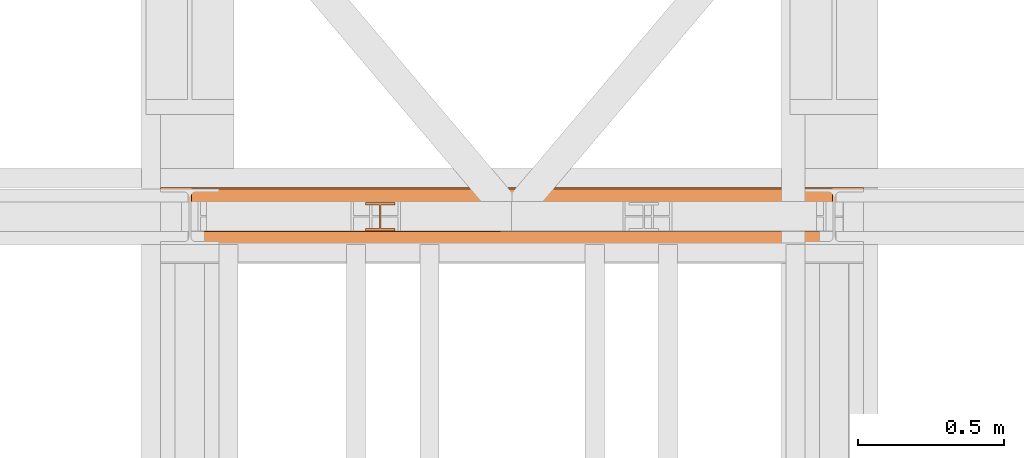
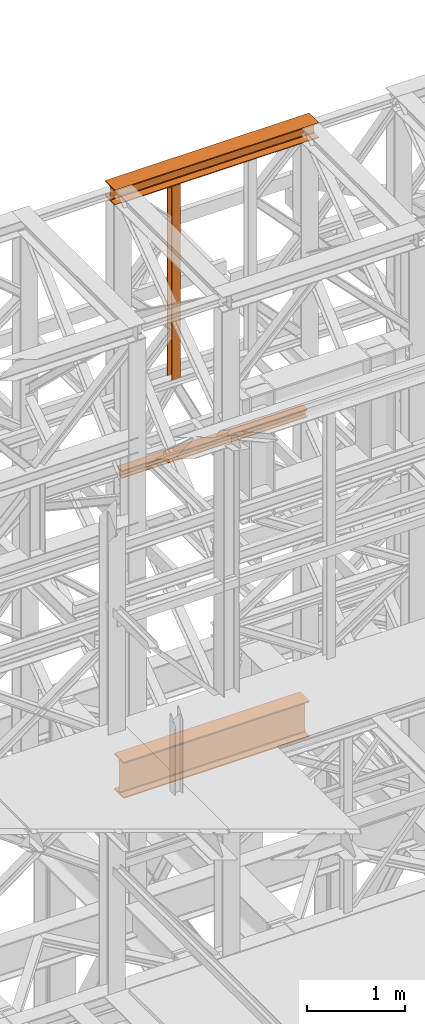
# One storey, part 162 of 208: 4 proxies.
"""IFC2X3 building model written with IfcOpenShell, lengths in millimetres."""

from ifc_helpers import new_model, entity, si_unit, converted_unit, frame, origin, origin_with_axes, place, context, subcontext, project, spatial, faceted_brep, element, save


model = new_model("IFC2X3")

# Units and contexts
model_context = context("Model", 3, precision=1e-05, world=origin())
plan_context = context("Plan", 3, precision=1e-05, world=origin())
body_context = subcontext(model_context, "Body", "Model", "MODEL_VIEW")
ifc_project = project(units=[si_unit("LENGTHUNIT", "METRE", prefix="MILLI"), converted_unit("PLANEANGLEUNIT", "DEGREE", entity("IfcPlaneAngleMeasure", 0.0174532925199433), si_unit("PLANEANGLEUNIT", "RADIAN"), dimensions=[0, 0, 0, 0, 0, 0, 0]), si_unit("AREAUNIT", "SQUARE_METRE"), si_unit("VOLUMEUNIT", "CUBIC_METRE")], contexts=[model_context, plan_context])

# Building, storey
building_placement = place(None, origin())
building = spatial("IfcBuilding", under=ifc_project, at=building_placement, CompositionType="COMPLEX")
storey_placement = place(building_placement, origin_with_axes())
storey = spatial("IfcBuildingStorey", under=building, at=storey_placement, Name="Geschoss", CompositionType="ELEMENT")

# Proxies
proxy_1_placement = place(storey_placement, frame((3299.254968580828, -13857.57439657637, 4834.989987483023), z_axis=(0.0, 0.0, 1.0), x_axis=(1.0, 0.0, 0.0)))
element("IfcBuildingElementProxy", 1, at=proxy_1_placement, inside=storey, context=body_context, shape_type="Brep", body=[
    faceted_brep([(2188.009999895692, 0.01000000000021828, 450.0100178813937), (2188.009999895692, 190.0100125169756, 450.0100178813937), (2188.009999895692, 190.0100125169756, 435.4100240564349), (2188.009999895692, 120.7100073045494, 435.4100091552737), (2188.009999895692, 109.841562265754, 433.2347078418734), (2188.009999895692, 101.8853126263621, 425.2784563398363), (2188.009999895692, 99.71000619068764, 414.4100113010409), (2188.009999895692, 99.71000619068764, 35.60999167919181), (2188.009999895692, 101.8853126263621, 24.74154664039634), (2188.009999895692, 109.841562265754, 16.78529513835929), (2188.009999895692, 120.7100073045494, 14.60999382495902), (2188.009999895692, 190.0100125169756, 14.60999382495902), (2188.009999895692, 190.0100125169756, 0.01000000000021828), (2188.009999895692, 0.01000000000021828, 0.01000000000021828), (2188.009999895692, 0.01000000000021828, 14.60999382495902), (2188.009999895692, 69.3100052124264, 14.60999382495902), (2188.009999895692, 80.17845025122188, 16.78529513835929), (2188.009999895692, 88.13469989061377, 24.74154664039634), (2188.009999895692, 90.3100063262882, 35.60999167919181), (2188.009999895692, 90.3100063262882, 414.4100113010409), (2188.009999895692, 88.13469989061377, 425.2784563398363), (2188.009999895692, 80.17845025122188, 433.2347078418734), (2188.009999895692, 69.3100052124264, 435.4100091552737), (2188.009999895692, 0.01000000000021828, 435.4100240564349), (2188.009999895692, 190.0100125169756, 450.0100178813937), (2188.009999895692, 0.01000000000021828, 450.0100178813937), (0.01000000000021828, 0.01000000000021828, 450.0100178813937), (0.01000000000021828, 190.0100125169756, 450.0100178813937), (2188.009999895692, 190.0100125169756, 435.4100240564349), (2188.009999895692, 190.0100125169756, 450.0100178813937), (0.01000000000021828, 190.0100125169756, 450.0100178813937), (0.01000000000021828, 190.0100125169756, 435.4100240564349), (2188.009999895692, 120.7100073045494, 435.4100091552737), (2188.009999895692, 190.0100125169756, 435.4100240564349), (0.01000000000021828, 190.0100125169756, 435.4100240564349), (0.01000000000021828, 120.7100073045494, 435.4100091552737), (2188.009999895692, 109.841562265754, 433.2347078418734), (2188.009999895692, 120.7100073045494, 435.4100091552737), (0.01000000000021828, 120.7100073045494, 435.4100091552737), (0.01000000000021828, 109.841562265754, 433.2347078418734), (2188.009999895692, 101.8853126263621, 425.2784563398363), (2188.009999895692, 109.841562265754, 433.2347078418734), (0.01000000000021828, 109.841562265754, 433.2347078418734), (0.01000000000021828, 101.8853126263621, 425.2784563398363), (2188.009999895692, 99.71000619068764, 414.4100113010409), (2188.009999895692, 101.8853126263621, 425.2784563398363), (0.01000000000021828, 101.8853126263621, 425.2784563398363), (0.01000000000021828, 99.71000619068764, 414.4100113010409), (2188.009999895692, 99.71000619068764, 35.60999167919181), (2188.009999895692, 99.71000619068764, 414.4100113010409), (0.01000000000021828, 99.71000619068764, 414.4100113010409), (0.01000000000021828, 99.71000619068764, 35.60999167919181), (2188.009999895692, 101.8853126263621, 24.74154664039634), (2188.009999895692, 99.71000619068764, 35.60999167919181), (0.01000000000021828, 99.71000619068764, 35.60999167919181), (0.01000000000021828, 101.8853126263621, 24.74154664039634), (2188.009999895692, 109.841562265754, 16.78529513835929), (2188.009999895692, 101.8853126263621, 24.74154664039634), (0.01000000000021828, 101.8853126263621, 24.74154664039634), (0.01000000000021828, 109.841562265754, 16.78529513835929), (2188.009999895692, 120.7100073045494, 14.60999382495902), (2188.009999895692, 109.841562265754, 16.78529513835929), (0.01000000000021828, 109.841562265754, 16.78529513835929), (0.01000000000021828, 120.7100073045494, 14.60999382495902), (2188.009999895692, 190.0100125169756, 14.60999382495902), (2188.009999895692, 120.7100073045494, 14.60999382495902), (0.01000000000021828, 120.7100073045494, 14.60999382495902), (0.01000000000021828, 190.0100125169756, 14.60999382495902), (2188.009999895692, 190.0100125169756, 0.01000000000021828), (2188.009999895692, 190.0100125169756, 14.60999382495902), (0.01000000000021828, 190.0100125169756, 14.60999382495902), (0.01000000000021828, 190.0100125169756, 0.01000000000021828), (2188.009999895692, 0.01000000000021828, 0.01000000000021828), (2188.009999895692, 190.0100125169756, 0.01000000000021828), (0.01000000000021828, 190.0100125169756, 0.01000000000021828), (0.01000000000021828, 0.01000000000021828, 0.01000000000021828), (2188.009999895692, 0.01000000000021828, 14.60999382495902), (2188.009999895692, 0.01000000000021828, 0.01000000000021828), (0.01000000000021828, 0.01000000000021828, 0.01000000000021828), (0.01000000000021828, 0.01000000000021828, 14.60999382495902), (2188.009999895692, 69.3100052124264, 14.60999382495902), (2188.009999895692, 0.01000000000021828, 14.60999382495902), (0.01000000000021828, 0.01000000000021828, 14.60999382495902), (0.01000000000021828, 69.3100052124264, 14.60999382495902), (2188.009999895692, 80.17845025122188, 16.78529513835929), (2188.009999895692, 69.3100052124264, 14.60999382495902), (0.01000000000021828, 69.3100052124264, 14.60999382495902), (0.01000000000021828, 80.17845025122188, 16.78529513835929), (2188.009999895692, 88.13469989061377, 24.74154664039634), (2188.009999895692, 80.17845025122188, 16.78529513835929), (0.01000000000021828, 80.17845025122188, 16.78529513835929), (0.01000000000021828, 88.13469989061377, 24.74154664039634), (2188.009999895692, 90.3100063262882, 35.60999167919181), (2188.009999895692, 88.13469989061377, 24.74154664039634), (0.01000000000021828, 88.13469989061377, 24.74154664039634), (0.01000000000021828, 90.3100063262882, 35.60999167919181), (2188.009999895692, 90.3100063262882, 414.4100113010409), (2188.009999895692, 90.3100063262882, 35.60999167919181), (0.01000000000021828, 90.3100063262882, 35.60999167919181), (0.01000000000021828, 90.3100063262882, 414.4100113010409), (2188.009999895692, 88.13469989061377, 425.2784563398363), (2188.009999895692, 90.3100063262882, 414.4100113010409), (0.01000000000021828, 90.3100063262882, 414.4100113010409), (0.01000000000021828, 88.13469989061377, 425.2784563398363), (2188.009999895692, 80.17845025122188, 433.2347078418734), (2188.009999895692, 88.13469989061377, 425.2784563398363), (0.01000000000021828, 88.13469989061377, 425.2784563398363), (0.01000000000021828, 80.17845025122188, 433.2347078418734), (2188.009999895692, 69.3100052124264, 435.4100091552737), (2188.009999895692, 80.17845025122188, 433.2347078418734), (0.01000000000021828, 80.17845025122188, 433.2347078418734), (0.01000000000021828, 69.3100052124264, 435.4100091552737), (2188.009999895692, 0.01000000000021828, 435.4100240564349), (2188.009999895692, 69.3100052124264, 435.4100091552737), (0.01000000000021828, 69.3100052124264, 435.4100091552737), (0.01000000000021828, 0.01000000000021828, 435.4100240564349), (2188.009999895692, 0.01000000000021828, 450.0100178813937), (2188.009999895692, 0.01000000000021828, 435.4100240564349), (0.01000000000021828, 0.01000000000021828, 435.4100240564349), (0.01000000000021828, 0.01000000000021828, 450.0100178813937), (0.01000000000021828, 0.01000000000021828, 450.0100178813937), (0.01000000000021828, 0.01000000000021828, 435.4100240564349), (0.01000000000021828, 69.3100052124264, 435.4100091552737), (0.01000000000021828, 80.17845025122188, 433.2347078418734), (0.01000000000021828, 88.13469989061377, 425.2784563398363), (0.01000000000021828, 90.3100063262882, 414.4100113010409), (0.01000000000021828, 90.3100063262882, 35.60999167919181), (0.01000000000021828, 88.13469989061377, 24.74154664039634), (0.01000000000021828, 80.17845025122188, 16.78529513835929), (0.01000000000021828, 69.3100052124264, 14.60999382495902), (0.01000000000021828, 0.01000000000021828, 14.60999382495902), (0.01000000000021828, 0.01000000000021828, 0.01000000000021828), (0.01000000000021828, 190.0100125169756, 0.01000000000021828), (0.01000000000021828, 190.0100125169756, 14.60999382495902), (0.01000000000021828, 120.7100073045494, 14.60999382495902), (0.01000000000021828, 109.841562265754, 16.78529513835929), (0.01000000000021828, 101.8853126263621, 24.74154664039634), (0.01000000000021828, 99.71000619068764, 35.60999167919181), (0.01000000000021828, 99.71000619068764, 414.4100113010409), (0.01000000000021828, 101.8853126263621, 425.2784563398363), (0.01000000000021828, 109.841562265754, 433.2347078418734), (0.01000000000021828, 120.7100073045494, 435.4100091552737), (0.01000000000021828, 190.0100125169756, 435.4100240564349), (0.01000000000021828, 190.0100125169756, 450.0100178813937)], [[[0, 1, 2, 3, 4, 5, 6, 7, 8, 9, 10, 11, 12, 13, 14, 15, 16, 17, 18, 19, 20, 21, 22, 23]], [[24, 25, 26, 27]], [[28, 29, 30, 31]], [[32, 33, 34, 35]], [[36, 37, 38, 39]], [[40, 41, 42, 43]], [[44, 45, 46, 47]], [[48, 49, 50, 51]], [[52, 53, 54, 55]], [[56, 57, 58, 59]], [[60, 61, 62, 63]], [[64, 65, 66, 67]], [[68, 69, 70, 71]], [[72, 73, 74, 75]], [[76, 77, 78, 79]], [[80, 81, 82, 83]], [[84, 85, 86, 87]], [[88, 89, 90, 91]], [[92, 93, 94, 95]], [[96, 97, 98, 99]], [[100, 101, 102, 103]], [[104, 105, 106, 107]], [[108, 109, 110, 111]], [[112, 113, 114, 115]], [[116, 117, 118, 119]], [[120, 121, 122, 123, 124, 125, 126, 127, 128, 129, 130, 131, 132, 133, 134, 135, 136, 137, 138, 139, 140, 141, 142, 143]]], orient=[[False], [False], [False], [False], [False], [False], [False], [False], [False], [False], [False], [False], [False], [False], [False], [False], [False], [False], [False], [False], [False], [False], [False], [False], [False], [False]]),
])
proxy_2_placement = place(storey_placement, frame((3193.254967038549, -13862.574391808, 12249.99005869381), z_axis=(0.0, 0.0, 1.0), x_axis=(1.0, 0.0, 0.0)))
element("IfcBuildingElementProxy", 2, at=proxy_2_placement, inside=storey, context=body_context, shape_type="Brep", body=[
    faceted_brep([(0.01000000000021828, 0.01000000000021828, 0.01000000000021828), (0.01000000000021828, 200.0100029802325, 0.01000000000021828), (0.01000000000021828, 200.0100029802325, 10.00999791383765), (0.01000000000021828, 121.2600035762789, 10.01000536441825), (0.01000000000021828, 111.9441915473344, 11.87455041170142), (0.01000000000021828, 105.1245498640838, 18.69419349193595), (0.01000000000021828, 103.2600015571716, 28.01000458955787), (0.01000000000021828, 103.2600015571716, 162.0100153779986), (0.01000000000021828, 105.1245498640838, 171.3258264756205), (0.01000000000021828, 111.9441915473344, 178.145469555855), (0.01000000000021828, 121.2600035762789, 180.0100146031382), (0.01000000000021828, 200.0100029802325, 180.0100146031382), (0.01000000000021828, 200.0100029802325, 190.0100125169756), (0.01000000000021828, 0.01000000000021828, 190.0100125169756), (0.01000000000021828, 0.01000000000021828, 180.0100146031382), (0.01000000000021828, 78.75999940395377, 180.0100146031382), (0.01000000000021828, 88.07581143289826, 178.145469555855), (0.01000000000021828, 94.89545311614893, 171.3258264756205), (0.01000000000021828, 96.76000142306111, 162.0100153779986), (0.01000000000021828, 96.76000142306111, 28.01000458955787), (0.01000000000021828, 94.89545311614893, 18.69419349193595), (0.01000000000021828, 88.07581143289826, 11.87455041170142), (0.01000000000021828, 78.75999940395377, 10.01000536441825), (0.01000000000021828, 0.01000000000021828, 10.00999791383765), (0.01000000000021828, 200.0100029802325, 0.01000000000021828), (0.01000000000021828, 0.01000000000021828, 0.01000000000021828), (2400.010002980234, 0.00999999999839929, 0.01000000000021828), (2400.010002980234, 200.0100029802306, 0.01000000000021828), (0.01000000000021828, 200.0100029802325, 10.00999791383765), (0.01000000000021828, 200.0100029802325, 0.01000000000021828), (2400.010002980234, 200.0100029802306, 0.01000000000021828), (2400.010002980234, 200.0100029802306, 10.00999791383765), (0.01000000000021828, 121.2600035762789, 10.01000536441825), (0.01000000000021828, 200.0100029802325, 10.00999791383765), (2400.010002980234, 200.0100029802306, 10.00999791383765), (2400.010002980234, 121.2600035762771, 10.01000536441825), (0.01000000000021828, 111.9441915473344, 11.87455041170142), (0.01000000000021828, 121.2600035762789, 10.01000536441825), (2400.010002980234, 121.2600035762771, 10.01000536441825), (2400.010002980234, 111.9441915473326, 11.87455041170142), (0.01000000000021828, 105.1245498640838, 18.69419349193595), (0.01000000000021828, 111.9441915473344, 11.87455041170142), (2400.010002980234, 111.9441915473326, 11.87455041170142), (2400.010002980234, 105.1245498640819, 18.69419349193595), (0.01000000000021828, 103.2600015571716, 28.01000458955787), (0.01000000000021828, 105.1245498640838, 18.69419349193595), (2400.010002980234, 105.1245498640819, 18.69419349193595), (2400.010002980234, 103.2600015571697, 28.01000458955787), (0.01000000000021828, 103.2600015571716, 162.0100153779986), (0.01000000000021828, 103.2600015571716, 28.01000458955787), (2400.010002980234, 103.2600015571697, 28.01000458955787), (2400.010002980234, 103.2600015571697, 162.0100153779986), (0.01000000000021828, 105.1245498640838, 171.3258264756205), (0.01000000000021828, 103.2600015571716, 162.0100153779986), (2400.010002980234, 103.2600015571697, 162.0100153779986), (2400.010002980234, 105.1245498640819, 171.3258264756205), (0.01000000000021828, 111.9441915473344, 178.145469555855), (0.01000000000021828, 105.1245498640838, 171.3258264756205), (2400.010002980234, 105.1245498640819, 171.3258264756205), (2400.010002980234, 111.9441915473326, 178.145469555855), (0.01000000000021828, 121.2600035762789, 180.0100146031382), (0.01000000000021828, 111.9441915473344, 178.145469555855), (2400.010002980234, 111.9441915473326, 178.145469555855), (2400.010002980234, 121.2600035762771, 180.0100146031382), (0.01000000000021828, 200.0100029802325, 180.0100146031382), (0.01000000000021828, 121.2600035762789, 180.0100146031382), (2400.010002980234, 121.2600035762771, 180.0100146031382), (2400.010002980234, 200.0100029802306, 180.0100146031382), (0.01000000000021828, 200.0100029802325, 190.0100125169756), (0.01000000000021828, 200.0100029802325, 180.0100146031382), (2400.010002980234, 200.0100029802306, 180.0100146031382), (2400.010002980234, 200.0100029802306, 190.0100125169756), (0.01000000000021828, 0.01000000000021828, 190.0100125169756), (0.01000000000021828, 200.0100029802325, 190.0100125169756), (2400.010002980234, 200.0100029802306, 190.0100125169756), (2400.010002980234, 0.00999999999839929, 190.0100125169756), (0.01000000000021828, 0.01000000000021828, 180.0100146031382), (0.01000000000021828, 0.01000000000021828, 190.0100125169756), (2400.010002980234, 0.00999999999839929, 190.0100125169756), (2400.010002980234, 0.00999999999839929, 180.0100146031382), (0.01000000000021828, 78.75999940395377, 180.0100146031382), (0.01000000000021828, 0.01000000000021828, 180.0100146031382), (2400.010002980234, 0.00999999999839929, 180.0100146031382), (2400.010002980234, 78.75999940395195, 180.0100146031382), (0.01000000000021828, 88.07581143289826, 178.145469555855), (0.01000000000021828, 78.75999940395377, 180.0100146031382), (2400.010002980234, 78.75999940395195, 180.0100146031382), (2400.010002980234, 88.07581143289644, 178.145469555855), (0.01000000000021828, 94.89545311614893, 171.3258264756205), (0.01000000000021828, 88.07581143289826, 178.145469555855), (2400.010002980234, 88.07581143289644, 178.145469555855), (2400.010002980234, 94.89545311614711, 171.3258264756205), (0.01000000000021828, 96.76000142306111, 162.0100153779986), (0.01000000000021828, 94.89545311614893, 171.3258264756205), (2400.010002980234, 94.89545311614711, 171.3258264756205), (2400.010002980234, 96.7600014230593, 162.0100153779986), (0.01000000000021828, 96.76000142306111, 28.01000458955787), (0.01000000000021828, 96.76000142306111, 162.0100153779986), (2400.010002980234, 96.7600014230593, 162.0100153779986), (2400.010002980234, 96.7600014230593, 28.01000458955787), (0.01000000000021828, 94.89545311614893, 18.69419349193595), (0.01000000000021828, 96.76000142306111, 28.01000458955787), (2400.010002980234, 96.7600014230593, 28.01000458955787), (2400.010002980234, 94.89545311614711, 18.69419349193595), (0.01000000000021828, 88.07581143289826, 11.87455041170142), (0.01000000000021828, 94.89545311614893, 18.69419349193595), (2400.010002980234, 94.89545311614711, 18.69419349193595), (2400.010002980234, 88.07581143289644, 11.87455041170142), (0.01000000000021828, 78.75999940395377, 10.01000536441825), (0.01000000000021828, 88.07581143289826, 11.87455041170142), (2400.010002980234, 88.07581143289644, 11.87455041170142), (2400.010002980234, 78.75999940395195, 10.01000536441825), (0.01000000000021828, 0.01000000000021828, 10.00999791383765), (0.01000000000021828, 78.75999940395377, 10.01000536441825), (2400.010002980234, 78.75999940395195, 10.01000536441825), (2400.010002980234, 0.00999999999839929, 10.00999791383765), (0.01000000000021828, 0.01000000000021828, 0.01000000000021828), (0.01000000000021828, 0.01000000000021828, 10.00999791383765), (2400.010002980234, 0.00999999999839929, 10.00999791383765), (2400.010002980234, 0.00999999999839929, 0.01000000000021828), (2400.010002980234, 0.00999999999839929, 0.01000000000021828), (2400.010002980234, 0.00999999999839929, 10.00999791383765), (2400.010002980234, 78.75999940395195, 10.01000536441825), (2400.010002980234, 88.07581143289644, 11.87455041170142), (2400.010002980234, 94.89545311614711, 18.69419349193595), (2400.010002980234, 96.7600014230593, 28.01000458955787), (2400.010002980234, 96.7600014230593, 162.0100153779986), (2400.010002980234, 94.89545311614711, 171.3258264756205), (2400.010002980234, 88.07581143289644, 178.145469555855), (2400.010002980234, 78.75999940395195, 180.0100146031382), (2400.010002980234, 0.00999999999839929, 180.0100146031382), (2400.010002980234, 0.00999999999839929, 190.0100125169756), (2400.010002980234, 200.0100029802306, 190.0100125169756), (2400.010002980234, 200.0100029802306, 180.0100146031382), (2400.010002980234, 121.2600035762771, 180.0100146031382), (2400.010002980234, 111.9441915473326, 178.145469555855), (2400.010002980234, 105.1245498640819, 171.3258264756205), (2400.010002980234, 103.2600015571697, 162.0100153779986), (2400.010002980234, 103.2600015571697, 28.01000458955787), (2400.010002980234, 105.1245498640819, 18.69419349193595), (2400.010002980234, 111.9441915473326, 11.87455041170142), (2400.010002980234, 121.2600035762771, 10.01000536441825), (2400.010002980234, 200.0100029802306, 10.00999791383765), (2400.010002980234, 200.0100029802306, 0.01000000000021828)], [[[0, 1, 2, 3, 4, 5, 6, 7, 8, 9, 10, 11, 12, 13, 14, 15, 16, 17, 18, 19, 20, 21, 22, 23]], [[24, 25, 26, 27]], [[28, 29, 30, 31]], [[32, 33, 34, 35]], [[36, 37, 38, 39]], [[40, 41, 42, 43]], [[44, 45, 46, 47]], [[48, 49, 50, 51]], [[52, 53, 54, 55]], [[56, 57, 58, 59]], [[60, 61, 62, 63]], [[64, 65, 66, 67]], [[68, 69, 70, 71]], [[72, 73, 74, 75]], [[76, 77, 78, 79]], [[80, 81, 82, 83]], [[84, 85, 86, 87]], [[88, 89, 90, 91]], [[92, 93, 94, 95]], [[96, 97, 98, 99]], [[100, 101, 102, 103]], [[104, 105, 106, 107]], [[108, 109, 110, 111]], [[112, 113, 114, 115]], [[116, 117, 118, 119]], [[120, 121, 122, 123, 124, 125, 126, 127, 128, 129, 130, 131, 132, 133, 134, 135, 136, 137, 138, 139, 140, 141, 142, 143]]], orient=[[False], [False], [False], [False], [False], [False], [False], [False], [False], [False], [False], [False], [False], [False], [False], [False], [False], [False], [False], [False], [False], [False], [False], [False], [False], [False]]),
])
proxy_3_placement = place(storey_placement, frame((3893.254968528663, -13810.57439404318, 9798.105713222345), z_axis=(0.0, 0.0, 1.0), x_axis=(1.0, 0.0, 0.0)))
element("IfcBuildingElementProxy", 3, at=proxy_3_placement, inside=storey, context=body_context, shape_type="Brep", body=[
    faceted_brep([(100.0100000000039, 88.01000000000022, 0.01000000000021828), (100.0100000000039, 96.01000000000022, 0.01000000000021828), (0.01000000000385626, 96.01000000000022, 0.01000000000021828), (0.01000000000385626, 88.01000000000022, 0.01000000000021828), (47.51000000000386, 88.01000000000022, 0.01000000000021828), (47.51000000000386, 8.010000000000218, 0.01000000000021828), (0.01000000000385626, 8.010000000000218, 0.01000000000021828), (0.01000000000385626, 0.01000000000021828, 0.01000000000021828), (100.0100000000039, 0.01000000000021828, 0.01000000000021828), (100.0100000000039, 8.010000000000218, 0.01000000000021828), (52.51000000000386, 8.010000000000218, 0.01000000000021828), (52.51000000000386, 88.01000000000022, 0.01000000000021828), (100.0100000000039, 96.01000000000022, 0.01000000000021828), (100.0100000000039, 88.01000000000022, 0.01000000000021828), (100.0100000000002, 88.01000000000022, 2451.894345471463), (100.0100000000002, 96.01000000000022, 2451.894345471463), (0.01000000000385626, 96.01000000000022, 0.01000000000021828), (100.0100000000039, 96.01000000000022, 0.01000000000021828), (100.0100000000002, 96.01000000000022, 2451.894345471463), (0.01000000000021828, 96.01000000000022, 2451.894345471463), (0.01000000000385626, 88.01000000000022, 0.01000000000021828), (0.01000000000385626, 96.01000000000022, 0.01000000000021828), (0.01000000000021828, 96.01000000000022, 2451.894345471463), (0.01000000000021828, 88.01000000000022, 2451.894345471463), (47.51000000000386, 88.01000000000022, 0.01000000000021828), (0.01000000000385626, 88.01000000000022, 0.01000000000021828), (0.01000000000021828, 88.01000000000022, 2451.894345471463), (47.51000000000022, 88.01000000000022, 2451.894345471463), (47.51000000000386, 8.010000000000218, 0.01000000000021828), (47.51000000000386, 88.01000000000022, 0.01000000000021828), (47.51000000000022, 88.01000000000022, 2451.894345471463), (47.51000000000022, 8.010000000000218, 2451.894345471463), (0.01000000000385626, 8.010000000000218, 0.01000000000021828), (47.51000000000386, 8.010000000000218, 0.01000000000021828), (47.51000000000022, 8.010000000000218, 2451.894345471463), (0.01000000000021828, 8.010000000000218, 2451.894345471463), (0.01000000000385626, 0.01000000000021828, 0.01000000000021828), (0.01000000000385626, 8.010000000000218, 0.01000000000021828), (0.01000000000021828, 8.010000000000218, 2451.894345471463), (0.01000000000021828, 0.01000000000021828, 2451.894345471463), (100.0100000000039, 0.01000000000021828, 0.01000000000021828), (0.01000000000385626, 0.01000000000021828, 0.01000000000021828), (0.01000000000021828, 0.01000000000021828, 2451.894345471463), (100.0100000000002, 0.01000000000021828, 2451.894345471463), (100.0100000000039, 8.010000000000218, 0.01000000000021828), (100.0100000000039, 0.01000000000021828, 0.01000000000021828), (100.0100000000002, 0.01000000000021828, 2451.894345471463), (100.0100000000002, 8.010000000000218, 2451.894345471463), (52.51000000000386, 8.010000000000218, 0.01000000000021828), (100.0100000000039, 8.010000000000218, 0.01000000000021828), (100.0100000000002, 8.010000000000218, 2451.894345471463), (52.51000000000022, 8.010000000000218, 2451.894345471463), (52.51000000000386, 88.01000000000022, 0.01000000000021828), (52.51000000000386, 8.010000000000218, 0.01000000000021828), (52.51000000000022, 8.010000000000218, 2451.894345471463), (52.51000000000022, 88.01000000000022, 2451.894345471463), (100.0100000000039, 88.01000000000022, 0.01000000000021828), (52.51000000000386, 88.01000000000022, 0.01000000000021828), (52.51000000000022, 88.01000000000022, 2451.894345471463), (100.0100000000002, 88.01000000000022, 2451.894345471463), (100.0100000000002, 88.01000000000022, 2451.894345471463), (52.51000000000022, 88.01000000000022, 2451.894345471463), (52.51000000000022, 8.010000000000218, 2451.894345471463), (100.0100000000002, 8.010000000000218, 2451.894345471463), (100.0100000000002, 0.01000000000021828, 2451.894345471463), (0.01000000000021828, 0.01000000000021828, 2451.894345471463), (0.01000000000021828, 8.010000000000218, 2451.894345471463), (47.51000000000022, 8.010000000000218, 2451.894345471463), (47.51000000000022, 88.01000000000022, 2451.894345471463), (0.01000000000021828, 88.01000000000022, 2451.894345471463), (0.01000000000021828, 96.01000000000022, 2451.894345471463), (100.0100000000002, 96.01000000000022, 2451.894345471463)], [[[0, 1, 2, 3, 4, 5, 6, 7, 8, 9, 10, 11]], [[12, 13, 14, 15]], [[16, 17, 18, 19]], [[20, 21, 22, 23]], [[24, 25, 26, 27]], [[28, 29, 30, 31]], [[32, 33, 34, 35]], [[36, 37, 38, 39]], [[40, 41, 42, 43]], [[44, 45, 46, 47]], [[48, 49, 50, 51]], [[52, 53, 54, 55]], [[56, 57, 58, 59]], [[60, 61, 62, 63, 64, 65, 66, 67, 68, 69, 70, 71]]], orient=[[False], [False], [False], [False], [False], [False], [False], [False], [False], [False], [False], [False], [False], [False]]),
])
proxy_4_placement = place(storey_placement, frame((3305.189158585883, -13812.57439031789, 8785.007354628786), z_axis=(0.0, 0.0, 1.0), x_axis=(1.0, 0.0, 0.0)))
element("IfcBuildingElementProxy", 4, at=proxy_4_placement, inside=storey, context=body_context, shape_type="Brep", body=[
    faceted_brep([(2184.825809875727, 0.01000000000021828, 8.010000000000218), (2184.825809875727, 47.51000000000022, 8.010000000000218), (2184.825809875727, 47.51000000000022, 88.01000000000204), (2184.825809875727, 0.01000000000021828, 88.01000000000204), (2184.825809875727, 0.01000000000021828, 96.01000000000022), (2184.825809875727, 100.0100000000002, 96.01000000000022), (2184.825809875727, 100.0100000000002, 88.01000000000204), (2184.825809875727, 52.51000000000022, 88.01000000000204), (2184.825809875727, 52.51000000000022, 8.010000000000218), (2184.825809875727, 100.0100000000002, 8.010000000000218), (2184.825809875727, 100.0100000000002, 0.01000000000021828), (2184.825809875727, 0.01000000000021828, 0.01000000000021828), (2184.825809875727, 0.01000000000021828, 0.01000000000021828), (0.01000000000021828, 0.01000000000385626, 0.01000000000203727), (0.01000000000021828, 0.01000000000385626, 8.010000000000218), (2184.825809875727, 0.01000000000021828, 8.010000000000218), (2184.825809875727, 100.0100000000002, 0.01000000000021828), (0.01000000000021828, 100.0100000000039, 0.01000000000021828), (0.01000000000021828, 0.01000000000385626, 0.01000000000203727), (2184.825809875727, 0.01000000000021828, 0.01000000000021828), (2184.825809875727, 100.0100000000002, 8.010000000000218), (0.01000000000021828, 100.0100000000039, 8.010000000000218), (0.01000000000021828, 100.0100000000039, 0.01000000000021828), (2184.825809875727, 100.0100000000002, 0.01000000000021828), (2184.825809875727, 52.51000000000022, 8.010000000000218), (0.01000000000021828, 52.51000000000386, 8.010000000000218), (0.01000000000021828, 100.0100000000039, 8.010000000000218), (2184.825809875727, 100.0100000000002, 8.010000000000218), (2184.825809875727, 52.51000000000022, 88.01000000000204), (0.01000000000021828, 52.51000000000386, 88.01000000000204), (0.01000000000021828, 52.51000000000386, 8.010000000000218), (2184.825809875727, 52.51000000000022, 8.010000000000218), (2184.825809875727, 100.0100000000002, 88.01000000000204), (0.01000000000021828, 100.0100000000039, 88.01000000000204), (0.01000000000021828, 52.51000000000386, 88.01000000000204), (2184.825809875727, 52.51000000000022, 88.01000000000204), (2184.825809875727, 100.0100000000002, 96.01000000000022), (0.01000000000021828, 100.0100000000039, 96.01000000000022), (0.01000000000021828, 100.0100000000039, 88.01000000000204), (2184.825809875727, 100.0100000000002, 88.01000000000204), (2184.825809875727, 0.01000000000021828, 96.01000000000022), (0.01000000000021828, 0.01000000000385626, 96.01000000000022), (0.01000000000021828, 100.0100000000039, 96.01000000000022), (2184.825809875727, 100.0100000000002, 96.01000000000022), (2184.825809875727, 0.01000000000021828, 88.01000000000204), (0.01000000000021828, 0.01000000000385626, 88.01000000000022), (0.01000000000021828, 0.01000000000385626, 96.01000000000022), (2184.825809875727, 0.01000000000021828, 96.01000000000022), (2184.825809875727, 47.51000000000022, 88.01000000000204), (0.01000000000021828, 47.51000000000386, 88.01000000000204), (0.01000000000021828, 0.01000000000385626, 88.01000000000022), (2184.825809875727, 0.01000000000021828, 88.01000000000204), (2184.825809875727, 47.51000000000022, 8.010000000000218), (0.01000000000021828, 47.51000000000386, 8.010000000000218), (0.01000000000021828, 47.51000000000386, 88.01000000000204), (2184.825809875727, 47.51000000000022, 88.01000000000204), (2184.825809875727, 0.01000000000021828, 8.010000000000218), (0.01000000000021828, 0.01000000000385626, 8.010000000000218), (0.01000000000021828, 47.51000000000386, 8.010000000000218), (2184.825809875727, 47.51000000000022, 8.010000000000218), (0.01000000000021828, 0.01000000000385626, 8.010000000000218), (0.01000000000021828, 0.01000000000385626, 0.01000000000203727), (0.01000000000021828, 100.0100000000039, 0.01000000000021828), (0.01000000000021828, 100.0100000000039, 8.010000000000218), (0.01000000000021828, 52.51000000000386, 8.010000000000218), (0.01000000000021828, 52.51000000000386, 88.01000000000204), (0.01000000000021828, 100.0100000000039, 88.01000000000204), (0.01000000000021828, 100.0100000000039, 96.01000000000022), (0.01000000000021828, 0.01000000000385626, 96.01000000000022), (0.01000000000021828, 0.01000000000385626, 88.01000000000022), (0.01000000000021828, 47.51000000000386, 88.01000000000204), (0.01000000000021828, 47.51000000000386, 8.010000000000218)], [[[0, 1, 2, 3, 4, 5, 6, 7, 8, 9, 10, 11]], [[12, 13, 14, 15]], [[16, 17, 18, 19]], [[20, 21, 22, 23]], [[24, 25, 26, 27]], [[28, 29, 30, 31]], [[32, 33, 34, 35]], [[36, 37, 38, 39]], [[40, 41, 42, 43]], [[44, 45, 46, 47]], [[48, 49, 50, 51]], [[52, 53, 54, 55]], [[56, 57, 58, 59]], [[60, 61, 62, 63, 64, 65, 66, 67, 68, 69, 70, 71]]], orient=[[False], [False], [False], [False], [False], [False], [False], [False], [False], [False], [False], [False], [False], [False]]),
])

save(model, "model.ifc")
